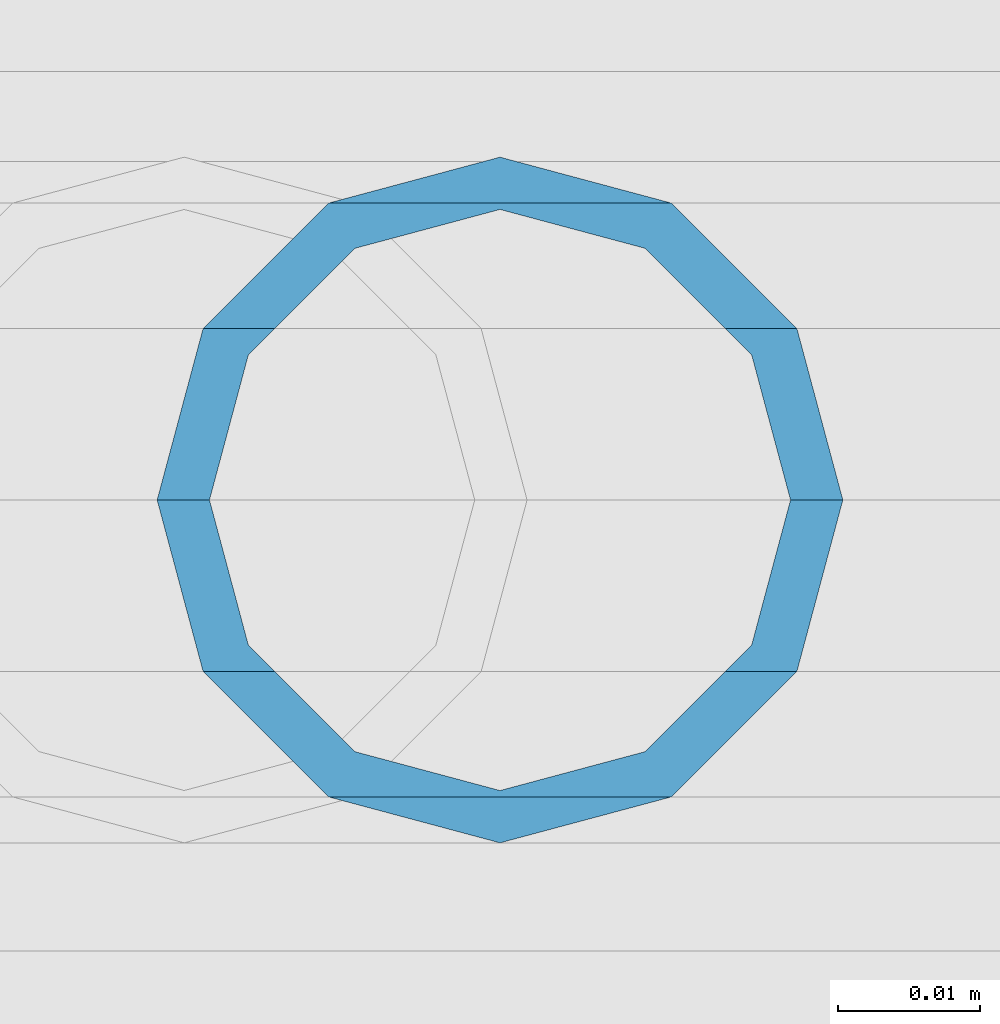
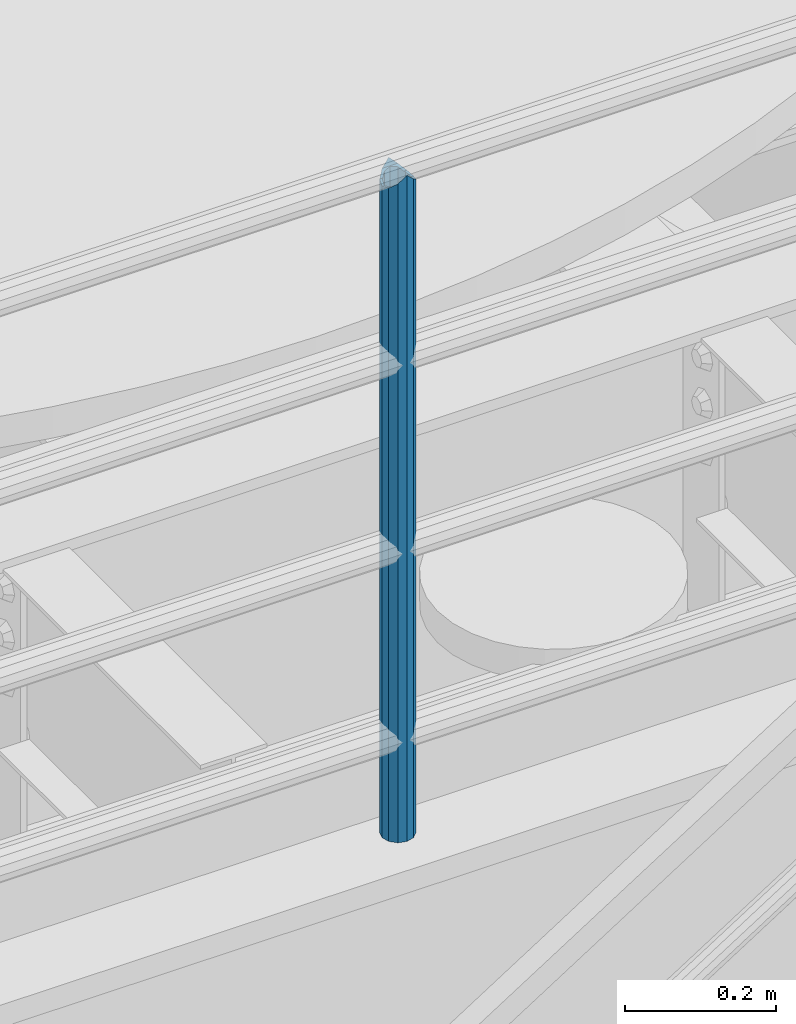
# One storey, part 628 of 1876: 1 column, 1 element without a shape of its own.
"""IFC2X3 building model written with IfcOpenShell, lengths in millimetres."""

from ifc_helpers import new_model, si_unit, frame, origin_with_axes, place, context, subcontext, project, spatial, faceted_brep, material, type_object, element, aggregate, save


model = new_model("IFC2X3")

# Units and contexts
model_context = context("Model", 3, precision=1e-05, world=origin_with_axes())
body_context = subcontext(model_context, "Body", "Model", "MODEL_VIEW")
ifc_project = project(units=[si_unit("LENGTHUNIT", "METRE", prefix="MILLI"), si_unit("AREAUNIT", "SQUARE_METRE"), si_unit("VOLUMEUNIT", "CUBIC_METRE"), si_unit("MASSUNIT", "GRAM", prefix="KILO"), si_unit("TIMEUNIT", "SECOND"), si_unit("PLANEANGLEUNIT", "RADIAN"), si_unit("SOLIDANGLEUNIT", "STERADIAN"), si_unit("THERMODYNAMICTEMPERATUREUNIT", "DEGREE_CELSIUS"), si_unit("LUMINOUSINTENSITYUNIT", "LUMEN")], contexts=[model_context])

# Site, building, storey
site_placement = place(None, origin_with_axes())
site = spatial("IfcSite", under=ifc_project, at=site_placement, CompositionType="ELEMENT")
building_placement = place(site_placement, origin_with_axes())
building = spatial("IfcBuilding", under=site, at=building_placement, Name="Undefined", CompositionType="ELEMENT")
storey_placement = place(building_placement, origin_with_axes())
storey = spatial("IfcBuildingStorey", under=building, at=storey_placement, Name="Undefined", CompositionType="ELEMENT", Elevation=0.0)

# Assembly, column
assembly_placement = place(storey_placement, origin_with_axes())
assembly = element("IfcElementAssembly", 1, at=assembly_placement, inside=storey, Name="RAIL", AssemblyPlace="NOTDEFINED", PredefinedType="RIGID_FRAME")
ifc_material = material()
column_type = type_object("IfcColumnType", Name="PIPE1-1/2SCH40", PredefinedType="NOTDEFINED")
column_placement = place(assembly_placement, frame((3959.22499997645, -4654.55000114554, 8153.4), z_axis=(0.0, 1.0, 0.0), x_axis=(0.0, 0.0, 1.0)))
column = element("IfcColumn", 2, at=column_placement, type_object=column_type, material=ifc_material, Name="POST", ObjectType="PIPE1-1/2SCH40", context=body_context, shape_type="Brep", body=[
    faceted_brep([(1076.325, 0.0, -24.1300000000001), (1064.26, 12.065, -20.8971929933186), (1064.26, -12.0650000000001, -20.8971929933186), (1054.93437856882, 17.7076214311801, 10.2235000000001), (1052.195, 20.4470000000001, 0.0), (1052.195, 24.13, 0.0), (1055.42780700668, 20.8971929933185, 12.0649999999996), (1055.42780700668, 15.8661214311869, 12.0649999999932), (1055.42780700668, 15.8661214311742, -12.065000000006), (1055.42780700668, 20.8971929933185, -12.0649999999996), (1054.93437856882, 17.7076214311801, -10.2235000000001), (1061.07042843786, 10.2235000000001, -17.7076214311801), (1063.80980700668, 0.0, -20.4470000000001), (1061.07042843786, -10.2235000000001, -17.7076214311801), (1055.42780700668, -15.8661214311742, -12.065000000006), (1055.42780700668, -20.8971929933184, -12.0649999999996), (1054.93437856882, -17.7076214311801, -10.2235000000001), (1052.195, -20.4470000000001, 0.0), (1052.195, -24.1300000000001, 0.0), (1054.93437856882, -17.7076214311801, 10.2235000000001), (1055.42780700668, -15.8661214311869, 12.0649999999932), (1055.42780700668, -20.8971929933184, 12.0649999999996), (1076.325, 0.0, 24.1300000000001), (1064.26, -12.0650000000001, 20.8971929933186), (1064.26, 12.065, 20.8971929933186), (1061.07042843787, -10.2235000000001, 17.7076214311801), (1063.80980700669, 0.0, 20.4470000000001), (1061.07042843787, 10.2235000000001, 17.7076214311801), (0.0, -20.8971929933184, -12.0649999999996), (0.0, -12.0650000000001, -20.8971929933186), (-1.45519152283669e-11, 0.0, -24.130000000001), (0.0, 12.0650000000001, -20.8971929933186), (0.0, 20.8971929933184, -12.0649999999996), (0.0, 24.1299999999992, 0.0), (0.0, 20.8971929933184, 12.0649999999996), (0.0, 12.0650000000001, 20.8971929933186), (-1.45519152283669e-11, 0.0, 24.130000000001), (0.0, -20.8971929933184, 12.0649999999996), (0.0, -24.1299999999992, 0.0), (0.0, -12.0650000000001, 20.8971929933186), (0.0, -17.7076214311803, -10.2235000000001), (0.0, -10.2235000000001, -17.7076214311801), (-1.45519152283669e-11, 0.0, -20.4470000000001), (0.0, 10.2235000000001, -17.7076214311801), (0.0, 17.7076214311803, -10.2235000000001), (0.0, 20.4469999999999, 0.0), (0.0, 17.7076214311803, 10.2235000000001), (0.0, 10.2235000000001, 17.7076214311801), (-1.45519152283669e-11, 0.0, 20.4470000000001), (0.0, -10.2235000000001, 17.7076214311801), (0.0, -17.7076214311803, 10.2235000000001), (0.0, -20.4469999999999, 0.0)], [[[0, 1, 2]], [[3, 4, 5, 6, 7]], [[8, 9, 5, 4, 10]], [[2, 1, 9, 8, 11, 12, 13, 14, 15]], [[15, 14, 16, 17, 18]], [[18, 17, 19, 20, 21]], [[22, 23, 24]], [[21, 20, 25, 26, 27, 7, 6, 24, 23]], [[28, 29, 2, 15]], [[29, 30, 0, 2]], [[30, 31, 1, 0]], [[31, 32, 9, 1]], [[32, 33, 5, 9]], [[33, 34, 6, 5]], [[34, 35, 24, 6]], [[35, 36, 22, 24]], [[37, 38, 18, 21]], [[39, 37, 21, 23]], [[36, 39, 23, 22]], [[38, 28, 15, 18]], [[37, 39, 36, 35, 34, 33, 32, 31, 30, 29, 28, 38], [40, 41, 42, 43, 44, 45, 46, 47, 48, 49, 50, 51]], [[49, 48, 26, 25]], [[19, 50, 49, 25, 20]], [[51, 50, 19, 17]], [[40, 51, 17, 16]], [[41, 40, 16, 14, 13]], [[42, 41, 13, 12]], [[43, 42, 12, 11]], [[10, 44, 43, 11, 8]], [[45, 44, 10, 4]], [[46, 45, 4, 3]], [[47, 46, 3, 7, 27]], [[48, 47, 27, 26]]]),
])
aggregate(assembly, [column])

save(model, "model.ifc")
